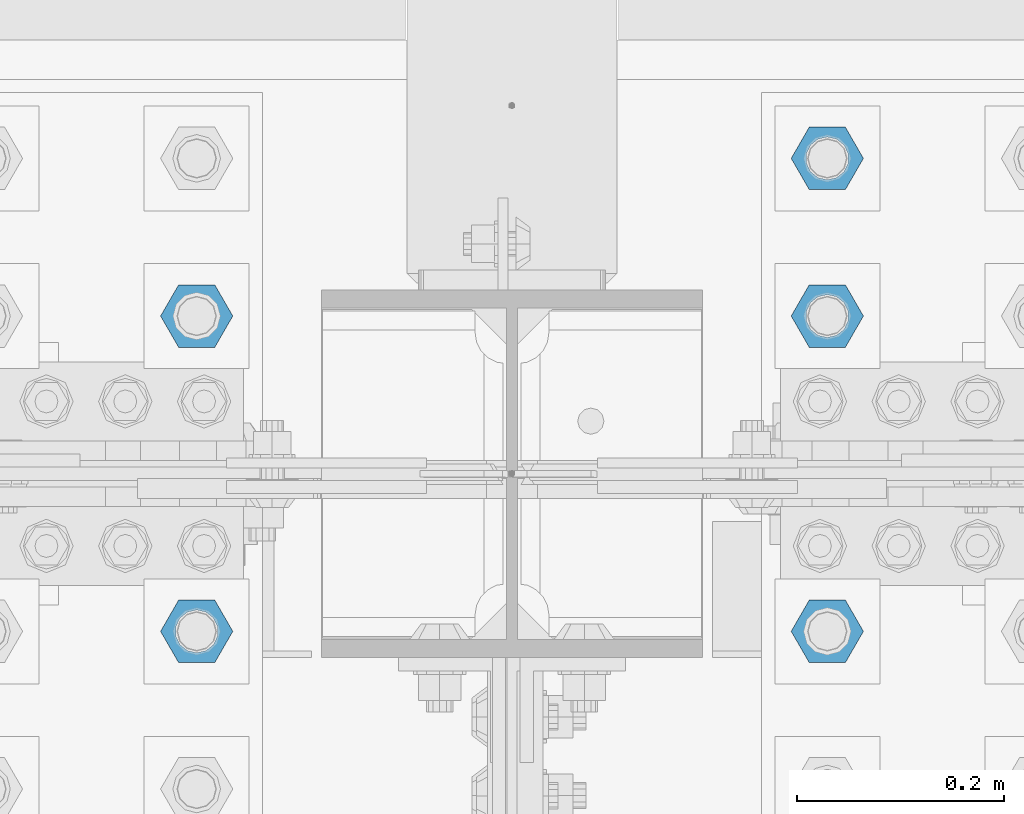
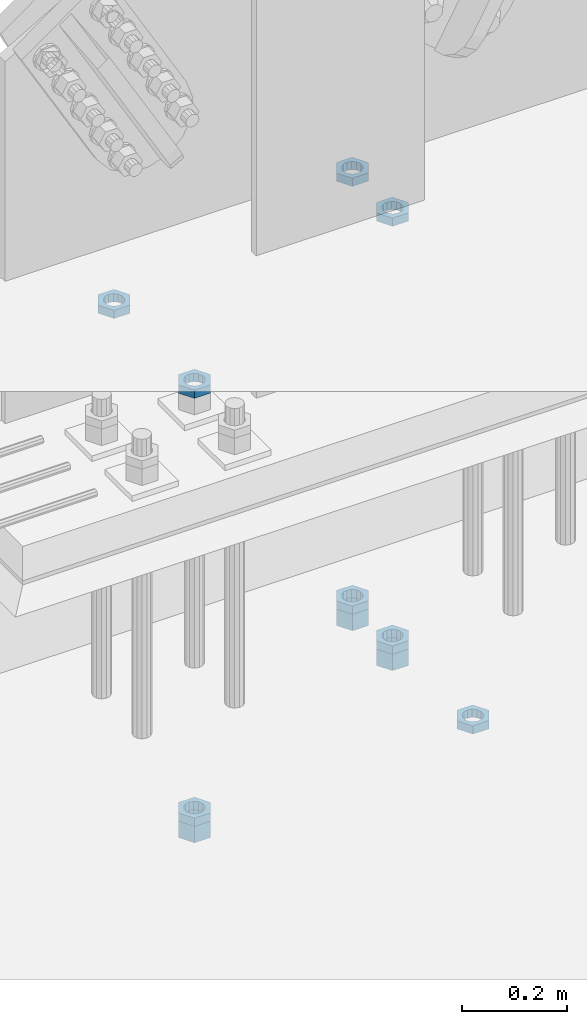
# One storey, part 2888 of 3843: 11 beams, 1 element without a shape of its own.
"""IFC2X3 building model written with IfcOpenShell, lengths in millimetres."""

from ifc_helpers import new_model, si_unit, frame, origin_with_axes, place, context, subcontext, project, spatial, faceted_brep, material, type_object, element, aggregate, save


model = new_model("IFC2X3")

# Units and contexts
model_context = context("Model", 3, precision=1e-05, world=origin_with_axes())
body_context = subcontext(model_context, "Body", "Model", "MODEL_VIEW")
ifc_project = project(units=[si_unit("LENGTHUNIT", "METRE", prefix="MILLI"), si_unit("AREAUNIT", "SQUARE_METRE"), si_unit("VOLUMEUNIT", "CUBIC_METRE"), si_unit("MASSUNIT", "GRAM", prefix="KILO"), si_unit("TIMEUNIT", "SECOND"), si_unit("PLANEANGLEUNIT", "RADIAN"), si_unit("SOLIDANGLEUNIT", "STERADIAN"), si_unit("THERMODYNAMICTEMPERATUREUNIT", "DEGREE_CELSIUS"), si_unit("LUMINOUSINTENSITYUNIT", "LUMEN")], contexts=[model_context])

# Site, building, storey
site_placement = place(None, origin_with_axes())
site = spatial("IfcSite", under=ifc_project, at=site_placement, CompositionType="ELEMENT")
building_placement = place(site_placement, origin_with_axes())
building = spatial("IfcBuilding", under=site, at=building_placement, Name="Undefined", CompositionType="ELEMENT")
storey_placement = place(building_placement, origin_with_axes())
storey = spatial("IfcBuildingStorey", under=building, at=storey_placement, Name="Undefined", CompositionType="ELEMENT", Elevation=0.0)

# Assembly, beams
assembly_placement = place(storey_placement, origin_with_axes())
assembly = element("IfcElementAssembly", 1, at=assembly_placement, inside=storey, Name="TEMPLATE", AssemblyPlace="NOTDEFINED", PredefinedType="RIGID_FRAME")
ifc_material = material(Name="STEEL/A572-50")
beam_type_1 = type_object("IfcBeamType", Name="1-1/2_HEAVY_HEX_NUT", PredefinedType="NOTDEFINED")
beam_1_placement = place(assembly_placement, frame((55626.0, 92062.3, 29210.0), z_axis=(0.0, -1.0, 0.0), x_axis=(0.0, 0.0, -1.0)))
beam_1 = element("IfcBeam", 2, at=beam_1_placement, type_object=beam_type_1, material=ifc_material, Name="NUT", ObjectType="1-1/2_HEAVY_HEX_NUT", context=body_context, shape_type="Brep", body=[
    faceted_brep([(0.0, -34.9199981689453, 0.0), (0.0, -17.4599990844727, -30.25), (38.0999999999985, -17.4599990844727, -30.25), (38.0999999999985, -34.9199981689453, 0.0), (0.0, 17.4599990844727, -30.25), (38.0999999999985, 17.4599990844727, -30.25), (0.0, 34.9199981689453, 0.0), (38.0999999999985, 34.9199981689453, 0.0), (0.0, 17.4599990844727, 30.25), (38.0999999999985, 17.4599990844727, 30.25), (0.0, -17.4599990844727, 30.25), (38.0999999999985, -17.4599990844727, 30.25), (0.0, 0.0, 20.6399993896484), (0.0, 8.9553601105581, 18.5959968835959), (38.0999999999985, 8.9553601105581, 18.5959968835959), (38.0999999999985, 0.0, 20.6399993896484), (0.0, 16.1370013209525, 12.8688291298167), (38.0999999999985, 16.1370013209525, 12.8688291298167), (0.0, 20.1225115123816, 4.59283194104501), (38.0999999999985, 20.1225115123816, 4.59283194104501), (0.0, 20.1225115123816, -4.59283194104501), (38.0999999999985, 20.1225115123816, -4.59283194104501), (0.0, 16.1370013209525, -12.8688291298167), (38.0999999999985, 16.1370013209525, -12.8688291298167), (0.0, 8.9553601105581, -18.5959968835959), (38.0999999999985, 8.9553601105581, -18.5959968835959), (0.0, 0.0, -20.6399993896484), (38.0999999999985, 0.0, -20.6399993896484), (0.0, -8.9553601105581, -18.5959968835959), (38.0999999999985, -8.9553601105581, -18.5959968835959), (0.0, -16.1370013209525, -12.8688291298167), (38.0999999999985, -16.1370013209525, -12.8688291298167), (0.0, -20.1225115123816, -4.59283194104501), (38.0999999999985, -20.1225115123816, -4.59283194104501), (0.0, -20.1225115123816, 4.59283194104501), (38.0999999999985, -20.1225115123816, 4.59283194104501), (0.0, -16.1370013209525, 12.8688291298167), (38.0999999999985, -16.1370013209525, 12.8688291298167), (0.0, -8.9553601105581, 18.5959968835959), (38.0999999999985, -8.9553601105581, 18.5959968835959)], [[[0, 1, 2, 3]], [[1, 4, 5, 2]], [[4, 6, 7, 5]], [[6, 8, 9, 7]], [[8, 10, 11, 9]], [[10, 0, 3, 11]], [[12, 13, 14, 15]], [[13, 16, 17, 14]], [[16, 18, 19, 17]], [[18, 20, 21, 19]], [[20, 22, 23, 21]], [[22, 24, 25, 23]], [[24, 26, 27, 25]], [[26, 28, 29, 27]], [[28, 30, 31, 29]], [[30, 32, 33, 31]], [[32, 34, 35, 33]], [[34, 36, 37, 35]], [[36, 38, 39, 37]], [[38, 12, 15, 39]], [[5, 7, 9, 11, 3, 2], [17, 19, 21, 23, 25, 27, 29, 31, 33, 35, 37, 39, 15, 14]], [[10, 8, 6, 4, 1, 0], [38, 36, 34, 32, 30, 28, 26, 24, 22, 20, 18, 16, 13, 12]]]),
])
beam_2_placement = place(assembly_placement, frame((56235.6, 92519.5, 29210.0), z_axis=(0.0, 1.0, 0.0), x_axis=(0.0, 0.0, -1.0)))
beam_2 = element("IfcBeam", 3, at=beam_2_placement, type_object=beam_type_1, material=ifc_material, Name="NUT", ObjectType="1-1/2_HEAVY_HEX_NUT", context=body_context, shape_type="Brep", body=[
    faceted_brep([(0.0, -34.9199981689453, 0.0), (0.0, -17.4599990844727, -30.25), (38.0999999999985, -17.4599990844727, -30.25), (38.0999999999985, -34.9199981689453, 0.0), (0.0, 17.4599990844727, -30.25), (38.0999999999985, 17.4599990844727, -30.25), (0.0, 34.9199981689453, 0.0), (38.0999999999985, 34.9199981689453, 0.0), (0.0, 17.4599990844727, 30.25), (38.0999999999985, 17.4599990844727, 30.25), (0.0, -17.4599990844727, 30.25), (38.0999999999985, -17.4599990844727, 30.25), (0.0, 0.0, 20.6399993896484), (0.0, 8.9553601105581, 18.5959968835959), (38.0999999999985, 8.9553601105581, 18.5959968835959), (38.0999999999985, 0.0, 20.6399993896484), (0.0, 16.1370013209525, 12.8688291298167), (38.0999999999985, 16.1370013209525, 12.8688291298167), (0.0, 20.1225115123816, 4.59283194104501), (38.0999999999985, 20.1225115123816, 4.59283194104501), (0.0, 20.1225115123816, -4.59283194104501), (38.0999999999985, 20.1225115123816, -4.59283194104501), (0.0, 16.1370013209525, -12.8688291298167), (38.0999999999985, 16.1370013209525, -12.8688291298167), (0.0, 8.9553601105581, -18.5959968835959), (38.0999999999985, 8.9553601105581, -18.5959968835959), (0.0, 0.0, -20.6399993896484), (38.0999999999985, 0.0, -20.6399993896484), (0.0, -8.9553601105581, -18.5959968835959), (38.0999999999985, -8.9553601105581, -18.5959968835959), (0.0, -16.1370013209525, -12.8688291298167), (38.0999999999985, -16.1370013209525, -12.8688291298167), (0.0, -20.1225115123816, -4.59283194104501), (38.0999999999985, -20.1225115123816, -4.59283194104501), (0.0, -20.1225115123816, 4.59283194104501), (38.0999999999985, -20.1225115123816, 4.59283194104501), (0.0, -16.1370013209525, 12.8688291298167), (38.0999999999985, -16.1370013209525, 12.8688291298167), (0.0, -8.9553601105581, 18.5959968835959), (38.0999999999985, -8.9553601105581, 18.5959968835959)], [[[0, 1, 2, 3]], [[1, 4, 5, 2]], [[4, 6, 7, 5]], [[6, 8, 9, 7]], [[8, 10, 11, 9]], [[10, 0, 3, 11]], [[12, 13, 14, 15]], [[13, 16, 17, 14]], [[16, 18, 19, 17]], [[18, 20, 21, 19]], [[20, 22, 23, 21]], [[22, 24, 25, 23]], [[24, 26, 27, 25]], [[26, 28, 29, 27]], [[28, 30, 31, 29]], [[30, 32, 33, 31]], [[32, 34, 35, 33]], [[34, 36, 37, 35]], [[36, 38, 39, 37]], [[38, 12, 15, 39]], [[5, 7, 9, 11, 3, 2], [17, 19, 21, 23, 25, 27, 29, 31, 33, 35, 37, 39, 15, 14]], [[10, 8, 6, 4, 1, 0], [38, 36, 34, 32, 30, 28, 26, 24, 22, 20, 18, 16, 13, 12]]]),
])
beam_3_placement = place(assembly_placement, frame((56235.6, 92367.1, 29210.0), z_axis=(0.0, 1.0, 0.0), x_axis=(0.0, 0.0, -1.0)))
beam_3 = element("IfcBeam", 4, at=beam_3_placement, type_object=beam_type_1, material=ifc_material, Name="NUT", ObjectType="1-1/2_HEAVY_HEX_NUT", context=body_context, shape_type="Brep", body=[
    faceted_brep([(0.0, -34.9199981689453, 0.0), (0.0, -17.4599990844727, -30.25), (38.0999999999985, -17.4599990844727, -30.25), (38.0999999999985, -34.9199981689453, 0.0), (0.0, 17.4599990844727, -30.25), (38.0999999999985, 17.4599990844727, -30.25), (0.0, 34.9199981689453, 0.0), (38.0999999999985, 34.9199981689453, 0.0), (0.0, 17.4599990844727, 30.25), (38.0999999999985, 17.4599990844727, 30.25), (0.0, -17.4599990844727, 30.25), (38.0999999999985, -17.4599990844727, 30.25), (0.0, 0.0, 20.6399993896484), (0.0, 8.9553601105581, 18.5959968835959), (38.0999999999985, 8.9553601105581, 18.5959968835959), (38.0999999999985, 0.0, 20.6399993896484), (0.0, 16.1370013209525, 12.8688291298167), (38.0999999999985, 16.1370013209525, 12.8688291298167), (0.0, 20.1225115123816, 4.59283194104501), (38.0999999999985, 20.1225115123816, 4.59283194104501), (0.0, 20.1225115123816, -4.59283194104501), (38.0999999999985, 20.1225115123816, -4.59283194104501), (0.0, 16.1370013209525, -12.8688291298167), (38.0999999999985, 16.1370013209525, -12.8688291298167), (0.0, 8.9553601105581, -18.5959968835959), (38.0999999999985, 8.9553601105581, -18.5959968835959), (0.0, 0.0, -20.6399993896484), (38.0999999999985, 0.0, -20.6399993896484), (0.0, -8.9553601105581, -18.5959968835959), (38.0999999999985, -8.9553601105581, -18.5959968835959), (0.0, -16.1370013209525, -12.8688291298167), (38.0999999999985, -16.1370013209525, -12.8688291298167), (0.0, -20.1225115123816, -4.59283194104501), (38.0999999999985, -20.1225115123816, -4.59283194104501), (0.0, -20.1225115123816, 4.59283194104501), (38.0999999999985, -20.1225115123816, 4.59283194104501), (0.0, -16.1370013209525, 12.8688291298167), (38.0999999999985, -16.1370013209525, 12.8688291298167), (0.0, -8.9553601105581, 18.5959968835959), (38.0999999999985, -8.9553601105581, 18.5959968835959)], [[[0, 1, 2, 3]], [[1, 4, 5, 2]], [[4, 6, 7, 5]], [[6, 8, 9, 7]], [[8, 10, 11, 9]], [[10, 0, 3, 11]], [[12, 13, 14, 15]], [[13, 16, 17, 14]], [[16, 18, 19, 17]], [[18, 20, 21, 19]], [[20, 22, 23, 21]], [[22, 24, 25, 23]], [[24, 26, 27, 25]], [[26, 28, 29, 27]], [[28, 30, 31, 29]], [[30, 32, 33, 31]], [[32, 34, 35, 33]], [[34, 36, 37, 35]], [[36, 38, 39, 37]], [[38, 12, 15, 39]], [[5, 7, 9, 11, 3, 2], [17, 19, 21, 23, 25, 27, 29, 31, 33, 35, 37, 39, 15, 14]], [[10, 8, 6, 4, 1, 0], [38, 36, 34, 32, 30, 28, 26, 24, 22, 20, 18, 16, 13, 12]]]),
])
beam_type_2 = type_object("IfcBeamType", Name="1-1/2_HALF_NUT", PredefinedType="NOTDEFINED")
beam_4_placement = place(assembly_placement, frame((55626.0, 92367.1, 30219.65), z_axis=(0.0, -1.0, 0.0), x_axis=(0.0, 0.0, -1.0)))
beam_4 = element("IfcBeam", 5, at=beam_4_placement, type_object=beam_type_2, material=ifc_material, Name="NUT", ObjectType="1-1/2_HALF_NUT", context=body_context, shape_type="Brep", body=[
    faceted_brep([(0.0, -34.9199981689453, 0.0), (0.0, -17.4599990844727, -30.25), (19.0500000000029, -17.4599990844727, -30.25), (19.0500000000029, -34.9199981689453, 0.0), (0.0, 17.4599990844727, -30.25), (19.0500000000029, 17.4599990844727, -30.25), (0.0, 34.9199981689453, 0.0), (19.0500000000029, 34.9199981689453, 0.0), (0.0, 17.4599990844727, 30.25), (19.0500000000029, 17.4599990844727, 30.25), (0.0, -17.4599990844727, 30.25), (19.0500000000029, -17.4599990844727, 30.25), (0.0, 0.0, 20.6399993896484), (0.0, 8.9553601105581, 18.5959968835959), (19.0500000000029, 8.95536011056538, 18.5959968835959), (19.0500000000029, 0.0, 20.6399993896484), (0.0, 16.1370013209525, 12.8688291298167), (19.0500000000029, 16.1370013209489, 12.8688291298167), (0.0, 20.1225115123816, 4.59283194104501), (19.0500000000029, 20.1225115123852, 4.59283194104501), (0.0, 20.1225115123816, -4.59283194104501), (19.0500000000029, 20.1225115123852, -4.59283194104501), (0.0, 16.1370013209525, -12.8688291298167), (19.0500000000029, 16.1370013209489, -12.8688291298167), (0.0, 8.9553601105581, -18.5959968835959), (19.0500000000029, 8.95536011056538, -18.5959968835959), (0.0, 0.0, -20.6399993896484), (19.0500000000029, 0.0, -20.6399993896484), (0.0, -8.9553601105581, -18.5959968835959), (19.0500000000029, -8.95536011056538, -18.5959968835959), (0.0, -16.1370013209525, -12.8688291298167), (19.0500000000029, -16.1370013209489, -12.8688291298167), (0.0, -20.1225115123816, -4.59283194104501), (19.0500000000029, -20.1225115123852, -4.59283194104501), (0.0, -20.1225115123816, 4.59283194104501), (19.0500000000029, -20.1225115123852, 4.59283194104501), (0.0, -16.1370013209525, 12.8688291298167), (19.0500000000029, -16.1370013209489, 12.8688291298167), (0.0, -8.9553601105581, 18.5959968835959), (19.0500000000029, -8.95536011056538, 18.5959968835959)], [[[0, 1, 2, 3]], [[1, 4, 5, 2]], [[4, 6, 7, 5]], [[6, 8, 9, 7]], [[8, 10, 11, 9]], [[10, 0, 3, 11]], [[12, 13, 14, 15]], [[13, 16, 17, 14]], [[16, 18, 19, 17]], [[18, 20, 21, 19]], [[20, 22, 23, 21]], [[22, 24, 25, 23]], [[24, 26, 27, 25]], [[26, 28, 29, 27]], [[28, 30, 31, 29]], [[30, 32, 33, 31]], [[32, 34, 35, 33]], [[34, 36, 37, 35]], [[36, 38, 39, 37]], [[38, 12, 15, 39]], [[5, 7, 9, 11, 3, 2], [17, 19, 21, 23, 25, 27, 29, 31, 33, 35, 37, 39, 15, 14]], [[10, 8, 6, 4, 1, 0], [38, 36, 34, 32, 30, 28, 26, 24, 22, 20, 18, 16, 13, 12]]]),
])
beam_5_placement = place(assembly_placement, frame((55626.0, 92062.3, 29229.05), z_axis=(0.0, -1.0, 0.0), x_axis=(0.0, 0.0, -1.0)))
beam_5 = element("IfcBeam", 6, at=beam_5_placement, type_object=beam_type_2, material=ifc_material, Name="NUT", ObjectType="1-1/2_HALF_NUT", context=body_context, shape_type="Brep", body=[
    faceted_brep([(0.0, -34.9199981689453, 0.0), (0.0, -17.4599990844727, -30.25), (19.0500000000029, -17.4599990844727, -30.25), (19.0500000000029, -34.9199981689453, 0.0), (0.0, 17.4599990844727, -30.25), (19.0500000000029, 17.4599990844727, -30.25), (0.0, 34.9199981689453, 0.0), (19.0500000000029, 34.9199981689453, 0.0), (0.0, 17.4599990844727, 30.25), (19.0500000000029, 17.4599990844727, 30.25), (0.0, -17.4599990844727, 30.25), (19.0500000000029, -17.4599990844727, 30.25), (0.0, 0.0, 20.6399993896484), (0.0, 8.9553601105581, 18.5959968835959), (19.0500000000029, 8.95536011056538, 18.5959968835959), (19.0500000000029, 0.0, 20.6399993896484), (0.0, 16.1370013209525, 12.8688291298167), (19.0500000000029, 16.1370013209489, 12.8688291298167), (0.0, 20.1225115123816, 4.59283194104501), (19.0500000000029, 20.1225115123852, 4.59283194104501), (0.0, 20.1225115123816, -4.59283194104501), (19.0500000000029, 20.1225115123852, -4.59283194104501), (0.0, 16.1370013209525, -12.8688291298167), (19.0500000000029, 16.1370013209489, -12.8688291298167), (0.0, 8.9553601105581, -18.5959968835959), (19.0500000000029, 8.95536011056538, -18.5959968835959), (0.0, 0.0, -20.6399993896484), (19.0500000000029, 0.0, -20.6399993896484), (0.0, -8.9553601105581, -18.5959968835959), (19.0500000000029, -8.95536011056538, -18.5959968835959), (0.0, -16.1370013209525, -12.8688291298167), (19.0500000000029, -16.1370013209489, -12.8688291298167), (0.0, -20.1225115123816, -4.59283194104501), (19.0500000000029, -20.1225115123852, -4.59283194104501), (0.0, -20.1225115123816, 4.59283194104501), (19.0500000000029, -20.1225115123852, 4.59283194104501), (0.0, -16.1370013209525, 12.8688291298167), (19.0500000000029, -16.1370013209489, 12.8688291298167), (0.0, -8.9553601105581, 18.5959968835959), (19.0500000000029, -8.95536011056538, 18.5959968835959)], [[[0, 1, 2, 3]], [[1, 4, 5, 2]], [[4, 6, 7, 5]], [[6, 8, 9, 7]], [[8, 10, 11, 9]], [[10, 0, 3, 11]], [[12, 13, 14, 15]], [[13, 16, 17, 14]], [[16, 18, 19, 17]], [[18, 20, 21, 19]], [[20, 22, 23, 21]], [[22, 24, 25, 23]], [[24, 26, 27, 25]], [[26, 28, 29, 27]], [[28, 30, 31, 29]], [[30, 32, 33, 31]], [[32, 34, 35, 33]], [[34, 36, 37, 35]], [[36, 38, 39, 37]], [[38, 12, 15, 39]], [[5, 7, 9, 11, 3, 2], [17, 19, 21, 23, 25, 27, 29, 31, 33, 35, 37, 39, 15, 14]], [[10, 8, 6, 4, 1, 0], [38, 36, 34, 32, 30, 28, 26, 24, 22, 20, 18, 16, 13, 12]]]),
])
beam_6_placement = place(assembly_placement, frame((55626.0, 92062.3, 30219.65), z_axis=(0.0, -1.0, 0.0), x_axis=(0.0, 0.0, -1.0)))
beam_6 = element("IfcBeam", 7, at=beam_6_placement, type_object=beam_type_2, material=ifc_material, Name="NUT", ObjectType="1-1/2_HALF_NUT", context=body_context, shape_type="Brep", body=[
    faceted_brep([(0.0, -34.9199981689453, 0.0), (0.0, -17.4599990844727, -30.25), (19.0500000000029, -17.4599990844727, -30.25), (19.0500000000029, -34.9199981689453, 0.0), (0.0, 17.4599990844727, -30.25), (19.0500000000029, 17.4599990844727, -30.25), (0.0, 34.9199981689453, 0.0), (19.0500000000029, 34.9199981689453, 0.0), (0.0, 17.4599990844727, 30.25), (19.0500000000029, 17.4599990844727, 30.25), (0.0, -17.4599990844727, 30.25), (19.0500000000029, -17.4599990844727, 30.25), (0.0, 0.0, 20.6399993896484), (0.0, 8.9553601105581, 18.5959968835959), (19.0500000000029, 8.95536011056538, 18.5959968835959), (19.0500000000029, 0.0, 20.6399993896484), (0.0, 16.1370013209525, 12.8688291298167), (19.0500000000029, 16.1370013209489, 12.8688291298167), (0.0, 20.1225115123816, 4.59283194104501), (19.0500000000029, 20.1225115123852, 4.59283194104501), (0.0, 20.1225115123816, -4.59283194104501), (19.0500000000029, 20.1225115123852, -4.59283194104501), (0.0, 16.1370013209525, -12.8688291298167), (19.0500000000029, 16.1370013209489, -12.8688291298167), (0.0, 8.9553601105581, -18.5959968835959), (19.0500000000029, 8.95536011056538, -18.5959968835959), (0.0, 0.0, -20.6399993896484), (19.0500000000029, 0.0, -20.6399993896484), (0.0, -8.9553601105581, -18.5959968835959), (19.0500000000029, -8.95536011056538, -18.5959968835959), (0.0, -16.1370013209525, -12.8688291298167), (19.0500000000029, -16.1370013209489, -12.8688291298167), (0.0, -20.1225115123816, -4.59283194104501), (19.0500000000029, -20.1225115123852, -4.59283194104501), (0.0, -20.1225115123816, 4.59283194104501), (19.0500000000029, -20.1225115123852, 4.59283194104501), (0.0, -16.1370013209525, 12.8688291298167), (19.0500000000029, -16.1370013209489, 12.8688291298167), (0.0, -8.9553601105581, 18.5959968835959), (19.0500000000029, -8.95536011056538, 18.5959968835959)], [[[0, 1, 2, 3]], [[1, 4, 5, 2]], [[4, 6, 7, 5]], [[6, 8, 9, 7]], [[8, 10, 11, 9]], [[10, 0, 3, 11]], [[12, 13, 14, 15]], [[13, 16, 17, 14]], [[16, 18, 19, 17]], [[18, 20, 21, 19]], [[20, 22, 23, 21]], [[22, 24, 25, 23]], [[24, 26, 27, 25]], [[26, 28, 29, 27]], [[28, 30, 31, 29]], [[30, 32, 33, 31]], [[32, 34, 35, 33]], [[34, 36, 37, 35]], [[36, 38, 39, 37]], [[38, 12, 15, 39]], [[5, 7, 9, 11, 3, 2], [17, 19, 21, 23, 25, 27, 29, 31, 33, 35, 37, 39, 15, 14]], [[10, 8, 6, 4, 1, 0], [38, 36, 34, 32, 30, 28, 26, 24, 22, 20, 18, 16, 13, 12]]]),
])
beam_7_placement = place(assembly_placement, frame((56235.6, 92519.5, 29229.05), z_axis=(0.0, 1.0, 0.0), x_axis=(0.0, 0.0, -1.0)))
beam_7 = element("IfcBeam", 8, at=beam_7_placement, type_object=beam_type_2, material=ifc_material, Name="NUT", ObjectType="1-1/2_HALF_NUT", context=body_context, shape_type="Brep", body=[
    faceted_brep([(0.0, -34.9199981689453, 0.0), (0.0, -17.4599990844727, -30.25), (19.0500000000029, -17.4599990844727, -30.25), (19.0500000000029, -34.9199981689453, 0.0), (0.0, 17.4599990844727, -30.25), (19.0500000000029, 17.4599990844727, -30.25), (0.0, 34.9199981689453, 0.0), (19.0500000000029, 34.9199981689453, 0.0), (0.0, 17.4599990844727, 30.25), (19.0500000000029, 17.4599990844727, 30.25), (0.0, -17.4599990844727, 30.25), (19.0500000000029, -17.4599990844727, 30.25), (0.0, 0.0, 20.6399993896484), (0.0, 8.9553601105581, 18.5959968835959), (19.0500000000029, 8.95536011056538, 18.5959968835959), (19.0500000000029, 0.0, 20.6399993896484), (0.0, 16.1370013209525, 12.8688291298167), (19.0500000000029, 16.1370013209489, 12.8688291298167), (0.0, 20.1225115123816, 4.59283194104501), (19.0500000000029, 20.1225115123852, 4.59283194104501), (0.0, 20.1225115123816, -4.59283194104501), (19.0500000000029, 20.1225115123852, -4.59283194104501), (0.0, 16.1370013209525, -12.8688291298167), (19.0500000000029, 16.1370013209489, -12.8688291298167), (0.0, 8.9553601105581, -18.5959968835959), (19.0500000000029, 8.95536011056538, -18.5959968835959), (0.0, 0.0, -20.6399993896484), (19.0500000000029, 0.0, -20.6399993896484), (0.0, -8.9553601105581, -18.5959968835959), (19.0500000000029, -8.95536011056538, -18.5959968835959), (0.0, -16.1370013209525, -12.8688291298167), (19.0500000000029, -16.1370013209489, -12.8688291298167), (0.0, -20.1225115123816, -4.59283194104501), (19.0500000000029, -20.1225115123852, -4.59283194104501), (0.0, -20.1225115123816, 4.59283194104501), (19.0500000000029, -20.1225115123852, 4.59283194104501), (0.0, -16.1370013209525, 12.8688291298167), (19.0500000000029, -16.1370013209489, 12.8688291298167), (0.0, -8.9553601105581, 18.5959968835959), (19.0500000000029, -8.95536011056538, 18.5959968835959)], [[[0, 1, 2, 3]], [[1, 4, 5, 2]], [[4, 6, 7, 5]], [[6, 8, 9, 7]], [[8, 10, 11, 9]], [[10, 0, 3, 11]], [[12, 13, 14, 15]], [[13, 16, 17, 14]], [[16, 18, 19, 17]], [[18, 20, 21, 19]], [[20, 22, 23, 21]], [[22, 24, 25, 23]], [[24, 26, 27, 25]], [[26, 28, 29, 27]], [[28, 30, 31, 29]], [[30, 32, 33, 31]], [[32, 34, 35, 33]], [[34, 36, 37, 35]], [[36, 38, 39, 37]], [[38, 12, 15, 39]], [[5, 7, 9, 11, 3, 2], [17, 19, 21, 23, 25, 27, 29, 31, 33, 35, 37, 39, 15, 14]], [[10, 8, 6, 4, 1, 0], [38, 36, 34, 32, 30, 28, 26, 24, 22, 20, 18, 16, 13, 12]]]),
])
beam_8_placement = place(assembly_placement, frame((56235.6, 92519.5, 30219.65), z_axis=(0.0, 1.0, 0.0), x_axis=(0.0, 0.0, -1.0)))
beam_8 = element("IfcBeam", 9, at=beam_8_placement, type_object=beam_type_2, material=ifc_material, Name="NUT", ObjectType="1-1/2_HALF_NUT", context=body_context, shape_type="Brep", body=[
    faceted_brep([(0.0, -34.9199981689453, 0.0), (0.0, -17.4599990844727, -30.25), (19.0500000000029, -17.4599990844727, -30.25), (19.0500000000029, -34.9199981689453, 0.0), (0.0, 17.4599990844727, -30.25), (19.0500000000029, 17.4599990844727, -30.25), (0.0, 34.9199981689453, 0.0), (19.0500000000029, 34.9199981689453, 0.0), (0.0, 17.4599990844727, 30.25), (19.0500000000029, 17.4599990844727, 30.25), (0.0, -17.4599990844727, 30.25), (19.0500000000029, -17.4599990844727, 30.25), (0.0, 0.0, 20.6399993896484), (0.0, 8.9553601105581, 18.5959968835959), (19.0500000000029, 8.95536011056538, 18.5959968835959), (19.0500000000029, 0.0, 20.6399993896484), (0.0, 16.1370013209525, 12.8688291298167), (19.0500000000029, 16.1370013209489, 12.8688291298167), (0.0, 20.1225115123816, 4.59283194104501), (19.0500000000029, 20.1225115123852, 4.59283194104501), (0.0, 20.1225115123816, -4.59283194104501), (19.0500000000029, 20.1225115123852, -4.59283194104501), (0.0, 16.1370013209525, -12.8688291298167), (19.0500000000029, 16.1370013209489, -12.8688291298167), (0.0, 8.9553601105581, -18.5959968835959), (19.0500000000029, 8.95536011056538, -18.5959968835959), (0.0, 0.0, -20.6399993896484), (19.0500000000029, 0.0, -20.6399993896484), (0.0, -8.9553601105581, -18.5959968835959), (19.0500000000029, -8.95536011056538, -18.5959968835959), (0.0, -16.1370013209525, -12.8688291298167), (19.0500000000029, -16.1370013209489, -12.8688291298167), (0.0, -20.1225115123816, -4.59283194104501), (19.0500000000029, -20.1225115123852, -4.59283194104501), (0.0, -20.1225115123816, 4.59283194104501), (19.0500000000029, -20.1225115123852, 4.59283194104501), (0.0, -16.1370013209525, 12.8688291298167), (19.0500000000029, -16.1370013209489, 12.8688291298167), (0.0, -8.9553601105581, 18.5959968835959), (19.0500000000029, -8.95536011056538, 18.5959968835959)], [[[0, 1, 2, 3]], [[1, 4, 5, 2]], [[4, 6, 7, 5]], [[6, 8, 9, 7]], [[8, 10, 11, 9]], [[10, 0, 3, 11]], [[12, 13, 14, 15]], [[13, 16, 17, 14]], [[16, 18, 19, 17]], [[18, 20, 21, 19]], [[20, 22, 23, 21]], [[22, 24, 25, 23]], [[24, 26, 27, 25]], [[26, 28, 29, 27]], [[28, 30, 31, 29]], [[30, 32, 33, 31]], [[32, 34, 35, 33]], [[34, 36, 37, 35]], [[36, 38, 39, 37]], [[38, 12, 15, 39]], [[5, 7, 9, 11, 3, 2], [17, 19, 21, 23, 25, 27, 29, 31, 33, 35, 37, 39, 15, 14]], [[10, 8, 6, 4, 1, 0], [38, 36, 34, 32, 30, 28, 26, 24, 22, 20, 18, 16, 13, 12]]]),
])
beam_9_placement = place(assembly_placement, frame((56235.6, 92367.1, 29229.05), z_axis=(0.0, 1.0, 0.0), x_axis=(0.0, 0.0, -1.0)))
beam_9 = element("IfcBeam", 10, at=beam_9_placement, type_object=beam_type_2, material=ifc_material, Name="NUT", ObjectType="1-1/2_HALF_NUT", context=body_context, shape_type="Brep", body=[
    faceted_brep([(0.0, -34.9199981689453, 0.0), (0.0, -17.4599990844727, -30.25), (19.0500000000029, -17.4599990844727, -30.25), (19.0500000000029, -34.9199981689453, 0.0), (0.0, 17.4599990844727, -30.25), (19.0500000000029, 17.4599990844727, -30.25), (0.0, 34.9199981689453, 0.0), (19.0500000000029, 34.9199981689453, 0.0), (0.0, 17.4599990844727, 30.25), (19.0500000000029, 17.4599990844727, 30.25), (0.0, -17.4599990844727, 30.25), (19.0500000000029, -17.4599990844727, 30.25), (0.0, 0.0, 20.6399993896484), (0.0, 8.9553601105581, 18.5959968835959), (19.0500000000029, 8.95536011056538, 18.5959968835959), (19.0500000000029, 0.0, 20.6399993896484), (0.0, 16.1370013209525, 12.8688291298167), (19.0500000000029, 16.1370013209489, 12.8688291298167), (0.0, 20.1225115123816, 4.59283194104501), (19.0500000000029, 20.1225115123852, 4.59283194104501), (0.0, 20.1225115123816, -4.59283194104501), (19.0500000000029, 20.1225115123852, -4.59283194104501), (0.0, 16.1370013209525, -12.8688291298167), (19.0500000000029, 16.1370013209489, -12.8688291298167), (0.0, 8.9553601105581, -18.5959968835959), (19.0500000000029, 8.95536011056538, -18.5959968835959), (0.0, 0.0, -20.6399993896484), (19.0500000000029, 0.0, -20.6399993896484), (0.0, -8.9553601105581, -18.5959968835959), (19.0500000000029, -8.95536011056538, -18.5959968835959), (0.0, -16.1370013209525, -12.8688291298167), (19.0500000000029, -16.1370013209489, -12.8688291298167), (0.0, -20.1225115123816, -4.59283194104501), (19.0500000000029, -20.1225115123852, -4.59283194104501), (0.0, -20.1225115123816, 4.59283194104501), (19.0500000000029, -20.1225115123852, 4.59283194104501), (0.0, -16.1370013209525, 12.8688291298167), (19.0500000000029, -16.1370013209489, 12.8688291298167), (0.0, -8.9553601105581, 18.5959968835959), (19.0500000000029, -8.95536011056538, 18.5959968835959)], [[[0, 1, 2, 3]], [[1, 4, 5, 2]], [[4, 6, 7, 5]], [[6, 8, 9, 7]], [[8, 10, 11, 9]], [[10, 0, 3, 11]], [[12, 13, 14, 15]], [[13, 16, 17, 14]], [[16, 18, 19, 17]], [[18, 20, 21, 19]], [[20, 22, 23, 21]], [[22, 24, 25, 23]], [[24, 26, 27, 25]], [[26, 28, 29, 27]], [[28, 30, 31, 29]], [[30, 32, 33, 31]], [[32, 34, 35, 33]], [[34, 36, 37, 35]], [[36, 38, 39, 37]], [[38, 12, 15, 39]], [[5, 7, 9, 11, 3, 2], [17, 19, 21, 23, 25, 27, 29, 31, 33, 35, 37, 39, 15, 14]], [[10, 8, 6, 4, 1, 0], [38, 36, 34, 32, 30, 28, 26, 24, 22, 20, 18, 16, 13, 12]]]),
])
beam_10_placement = place(assembly_placement, frame((56235.6, 92367.1, 30219.65), z_axis=(0.0, 1.0, 0.0), x_axis=(0.0, 0.0, -1.0)))
beam_10 = element("IfcBeam", 11, at=beam_10_placement, type_object=beam_type_2, material=ifc_material, Name="NUT", ObjectType="1-1/2_HALF_NUT", context=body_context, shape_type="Brep", body=[
    faceted_brep([(0.0, -34.9199981689453, 0.0), (0.0, -17.4599990844727, -30.25), (19.0500000000029, -17.4599990844727, -30.25), (19.0500000000029, -34.9199981689453, 0.0), (0.0, 17.4599990844727, -30.25), (19.0500000000029, 17.4599990844727, -30.25), (0.0, 34.9199981689453, 0.0), (19.0500000000029, 34.9199981689453, 0.0), (0.0, 17.4599990844727, 30.25), (19.0500000000029, 17.4599990844727, 30.25), (0.0, -17.4599990844727, 30.25), (19.0500000000029, -17.4599990844727, 30.25), (0.0, 0.0, 20.6399993896484), (0.0, 8.9553601105581, 18.5959968835959), (19.0500000000029, 8.95536011056538, 18.5959968835959), (19.0500000000029, 0.0, 20.6399993896484), (0.0, 16.1370013209525, 12.8688291298167), (19.0500000000029, 16.1370013209489, 12.8688291298167), (0.0, 20.1225115123816, 4.59283194104501), (19.0500000000029, 20.1225115123852, 4.59283194104501), (0.0, 20.1225115123816, -4.59283194104501), (19.0500000000029, 20.1225115123852, -4.59283194104501), (0.0, 16.1370013209525, -12.8688291298167), (19.0500000000029, 16.1370013209489, -12.8688291298167), (0.0, 8.9553601105581, -18.5959968835959), (19.0500000000029, 8.95536011056538, -18.5959968835959), (0.0, 0.0, -20.6399993896484), (19.0500000000029, 0.0, -20.6399993896484), (0.0, -8.9553601105581, -18.5959968835959), (19.0500000000029, -8.95536011056538, -18.5959968835959), (0.0, -16.1370013209525, -12.8688291298167), (19.0500000000029, -16.1370013209489, -12.8688291298167), (0.0, -20.1225115123816, -4.59283194104501), (19.0500000000029, -20.1225115123852, -4.59283194104501), (0.0, -20.1225115123816, 4.59283194104501), (19.0500000000029, -20.1225115123852, 4.59283194104501), (0.0, -16.1370013209525, 12.8688291298167), (19.0500000000029, -16.1370013209489, 12.8688291298167), (0.0, -8.9553601105581, 18.5959968835959), (19.0500000000029, -8.95536011056538, 18.5959968835959)], [[[0, 1, 2, 3]], [[1, 4, 5, 2]], [[4, 6, 7, 5]], [[6, 8, 9, 7]], [[8, 10, 11, 9]], [[10, 0, 3, 11]], [[12, 13, 14, 15]], [[13, 16, 17, 14]], [[16, 18, 19, 17]], [[18, 20, 21, 19]], [[20, 22, 23, 21]], [[22, 24, 25, 23]], [[24, 26, 27, 25]], [[26, 28, 29, 27]], [[28, 30, 31, 29]], [[30, 32, 33, 31]], [[32, 34, 35, 33]], [[34, 36, 37, 35]], [[36, 38, 39, 37]], [[38, 12, 15, 39]], [[5, 7, 9, 11, 3, 2], [17, 19, 21, 23, 25, 27, 29, 31, 33, 35, 37, 39, 15, 14]], [[10, 8, 6, 4, 1, 0], [38, 36, 34, 32, 30, 28, 26, 24, 22, 20, 18, 16, 13, 12]]]),
])
beam_11_placement = place(assembly_placement, frame((56235.6, 92062.3, 29229.05), z_axis=(0.0, 1.0, 0.0), x_axis=(0.0, 0.0, -1.0)))
beam_11 = element("IfcBeam", 12, at=beam_11_placement, type_object=beam_type_2, material=ifc_material, Name="NUT", ObjectType="1-1/2_HALF_NUT", context=body_context, shape_type="Brep", body=[
    faceted_brep([(0.0, -34.9199981689453, 0.0), (0.0, -17.4599990844727, -30.25), (19.0500000000029, -17.4599990844727, -30.25), (19.0500000000029, -34.9199981689453, 0.0), (0.0, 17.4599990844727, -30.25), (19.0500000000029, 17.4599990844727, -30.25), (0.0, 34.9199981689453, 0.0), (19.0500000000029, 34.9199981689453, 0.0), (0.0, 17.4599990844727, 30.25), (19.0500000000029, 17.4599990844727, 30.25), (0.0, -17.4599990844727, 30.25), (19.0500000000029, -17.4599990844727, 30.25), (0.0, 0.0, 20.6399993896484), (0.0, 8.9553601105581, 18.5959968835959), (19.0500000000029, 8.95536011056538, 18.5959968835959), (19.0500000000029, 0.0, 20.6399993896484), (0.0, 16.1370013209525, 12.8688291298167), (19.0500000000029, 16.1370013209489, 12.8688291298167), (0.0, 20.1225115123816, 4.59283194104501), (19.0500000000029, 20.1225115123852, 4.59283194104501), (0.0, 20.1225115123816, -4.59283194104501), (19.0500000000029, 20.1225115123852, -4.59283194104501), (0.0, 16.1370013209525, -12.8688291298167), (19.0500000000029, 16.1370013209489, -12.8688291298167), (0.0, 8.9553601105581, -18.5959968835959), (19.0500000000029, 8.95536011056538, -18.5959968835959), (0.0, 0.0, -20.6399993896484), (19.0500000000029, 0.0, -20.6399993896484), (0.0, -8.9553601105581, -18.5959968835959), (19.0500000000029, -8.95536011056538, -18.5959968835959), (0.0, -16.1370013209525, -12.8688291298167), (19.0500000000029, -16.1370013209489, -12.8688291298167), (0.0, -20.1225115123816, -4.59283194104501), (19.0500000000029, -20.1225115123852, -4.59283194104501), (0.0, -20.1225115123816, 4.59283194104501), (19.0500000000029, -20.1225115123852, 4.59283194104501), (0.0, -16.1370013209525, 12.8688291298167), (19.0500000000029, -16.1370013209489, 12.8688291298167), (0.0, -8.9553601105581, 18.5959968835959), (19.0500000000029, -8.95536011056538, 18.5959968835959)], [[[0, 1, 2, 3]], [[1, 4, 5, 2]], [[4, 6, 7, 5]], [[6, 8, 9, 7]], [[8, 10, 11, 9]], [[10, 0, 3, 11]], [[12, 13, 14, 15]], [[13, 16, 17, 14]], [[16, 18, 19, 17]], [[18, 20, 21, 19]], [[20, 22, 23, 21]], [[22, 24, 25, 23]], [[24, 26, 27, 25]], [[26, 28, 29, 27]], [[28, 30, 31, 29]], [[30, 32, 33, 31]], [[32, 34, 35, 33]], [[34, 36, 37, 35]], [[36, 38, 39, 37]], [[38, 12, 15, 39]], [[5, 7, 9, 11, 3, 2], [17, 19, 21, 23, 25, 27, 29, 31, 33, 35, 37, 39, 15, 14]], [[10, 8, 6, 4, 1, 0], [38, 36, 34, 32, 30, 28, 26, 24, 22, 20, 18, 16, 13, 12]]]),
])
aggregate(assembly, [beam_4, beam_5, beam_1, beam_6, beam_7, beam_2, beam_8, beam_9, beam_3, beam_10, beam_11])

save(model, "model.ifc")
